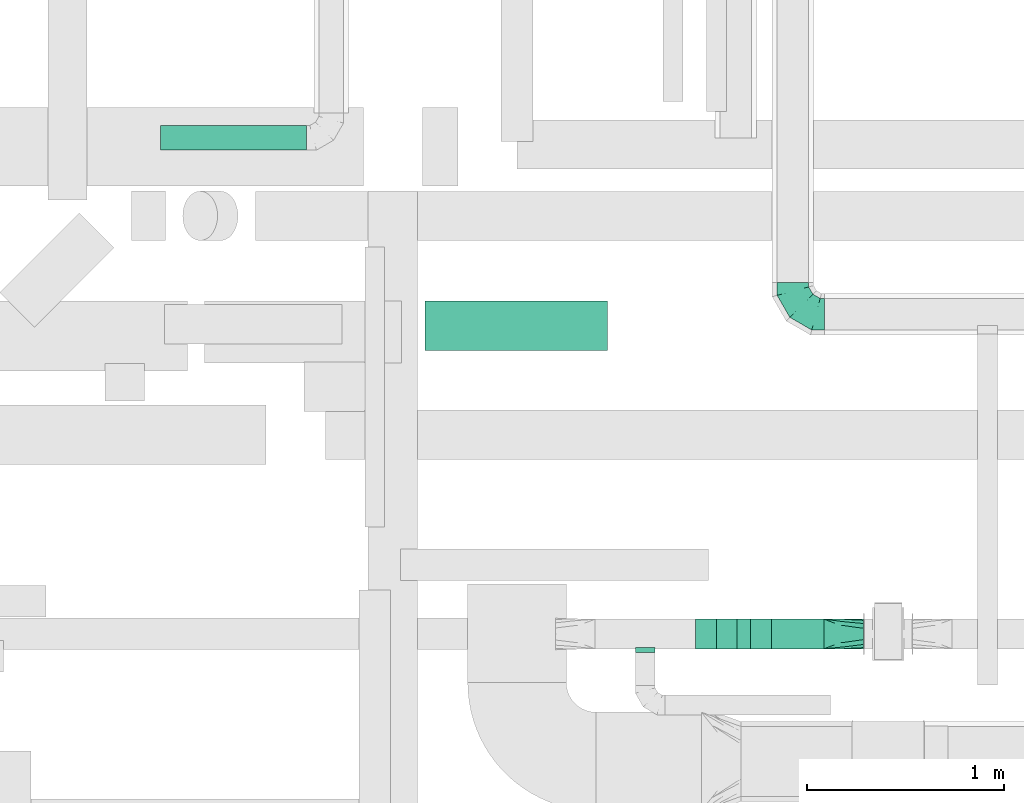
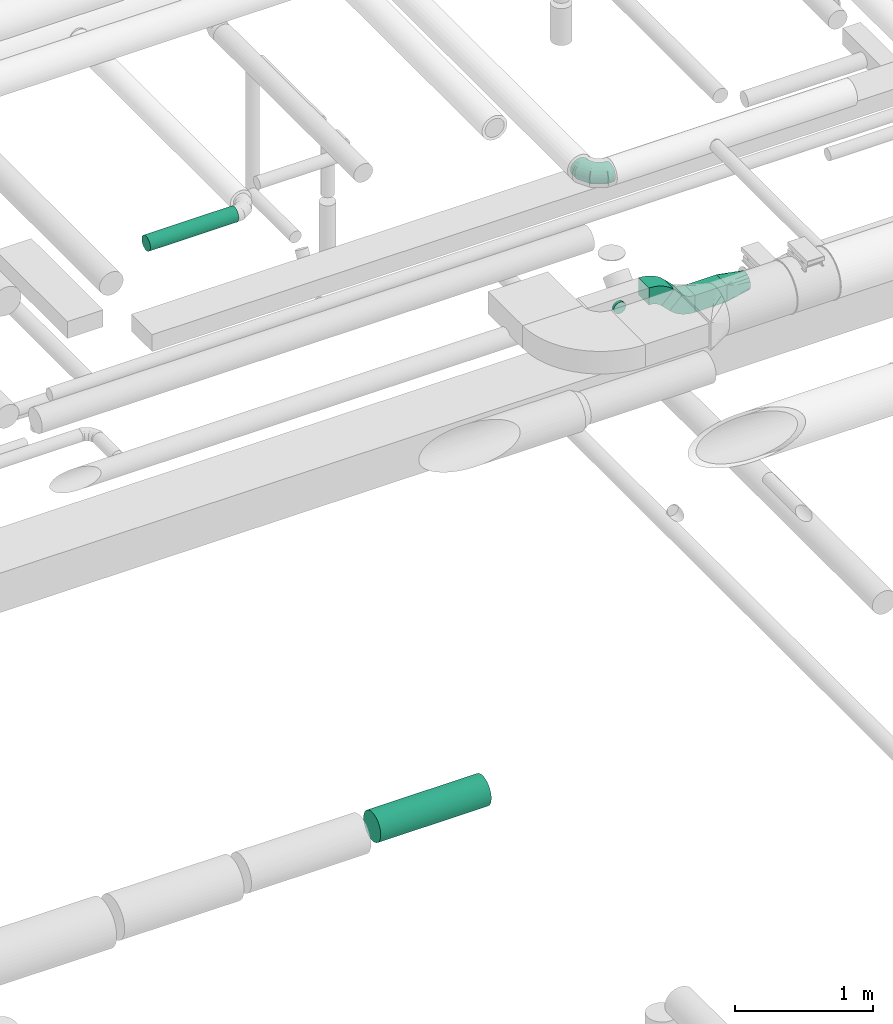
# One storey, part 210 of 337: 5 flow fittings, 4 flow segments.
"""IFC2X3 building model written with IfcOpenShell, lengths in millimetres."""

from ifc_helpers import new_model, entity, si_unit, converted_unit, derived_unit, direction, frame, frame_2d, origin, origin_2d_with_axis, place, context, subcontext, project, spatial, polyline, circle_curve, parameter, trimmed, segment, composite_curve, rectangle, circle, outline, extrude, faceted_brep, source, transform, mapped, material, type_object, type_shapes, element, save


model = new_model("IFC2X3")

# Units and contexts
model_context = context("Model", 3, precision=0.01, world=origin(), true_north=direction((6.12303176911189e-17, 1.0)))
body_context = subcontext(model_context, "Body", "Model", "MODEL_VIEW")
ifc_project = project(units=[si_unit("LENGTHUNIT", "METRE", prefix="MILLI"), si_unit("AREAUNIT", "SQUARE_METRE"), si_unit("VOLUMEUNIT", "CUBIC_METRE"), converted_unit("PLANEANGLEUNIT", "DEGREE", entity("IfcRatioMeasure", 0.0174532925199433), si_unit("PLANEANGLEUNIT", "RADIAN"), dimensions=[0, 0, 0, 0, 0, 0, 0]), si_unit("MASSUNIT", "GRAM", prefix="KILO"), derived_unit("MASSDENSITYUNIT", [(si_unit("MASSUNIT", "GRAM", prefix="KILO"), 1), (si_unit("LENGTHUNIT", "METRE"), -3)]), derived_unit("MOMENTOFINERTIAUNIT", [(si_unit("LENGTHUNIT", "METRE"), 4)]), si_unit("TIMEUNIT", "SECOND"), si_unit("FREQUENCYUNIT", "HERTZ"), si_unit("THERMODYNAMICTEMPERATUREUNIT", "DEGREE_CELSIUS"), derived_unit("THERMALTRANSMITTANCEUNIT", [(si_unit("MASSUNIT", "GRAM", prefix="KILO"), 1), (si_unit("THERMODYNAMICTEMPERATUREUNIT", "KELVIN"), -1), (si_unit("TIMEUNIT", "SECOND"), -3)]), derived_unit("VOLUMETRICFLOWRATEUNIT", [(si_unit("LENGTHUNIT", "METRE"), 3), (si_unit("TIMEUNIT", "SECOND"), -1)]), derived_unit("MASSFLOWRATEUNIT", [(si_unit("MASSUNIT", "GRAM", prefix="KILO"), 1), (si_unit("TIMEUNIT", "SECOND"), -1)]), derived_unit("ROTATIONALFREQUENCYUNIT", [(si_unit("TIMEUNIT", "SECOND"), -1)]), si_unit("ELECTRICCURRENTUNIT", "AMPERE"), si_unit("ELECTRICVOLTAGEUNIT", "VOLT"), si_unit("POWERUNIT", "WATT"), si_unit("FORCEUNIT", "NEWTON", prefix="KILO"), si_unit("ILLUMINANCEUNIT", "LUX"), si_unit("LUMINOUSFLUXUNIT", "LUMEN"), si_unit("LUMINOUSINTENSITYUNIT", "CANDELA"), derived_unit("USERDEFINED", [(si_unit("MASSUNIT", "GRAM", prefix="KILO"), -1), (si_unit("LENGTHUNIT", "METRE"), -2), (si_unit("TIMEUNIT", "SECOND"), 3), (si_unit("LUMINOUSFLUXUNIT", "LUMEN"), 1)]), derived_unit("LINEARVELOCITYUNIT", [(si_unit("LENGTHUNIT", "METRE"), 1), (si_unit("TIMEUNIT", "SECOND"), -1)]), si_unit("PRESSUREUNIT", "PASCAL"), derived_unit("USERDEFINED", [(si_unit("LENGTHUNIT", "METRE"), -2), (si_unit("MASSUNIT", "GRAM", prefix="KILO"), 1), (si_unit("TIMEUNIT", "SECOND"), -2)]), derived_unit("LINEARFORCEUNIT", [(si_unit("MASSUNIT", "GRAM", prefix="KILO"), 1), (si_unit("LENGTHUNIT", "METRE"), 1), (si_unit("TIMEUNIT", "SECOND"), -2), (si_unit("LENGTHUNIT", "METRE"), -1)]), derived_unit("PLANARFORCEUNIT", [(si_unit("MASSUNIT", "GRAM", prefix="KILO"), 1), (si_unit("LENGTHUNIT", "METRE"), 1), (si_unit("TIMEUNIT", "SECOND"), -2), (si_unit("LENGTHUNIT", "METRE"), -2)])], contexts=[model_context])

# Site, building, storey
site_placement = place(None, origin())
site = spatial("IfcSite", under=ifc_project, at=site_placement, CompositionType="ELEMENT")
building_placement = place(site_placement, origin())
building = spatial("IfcBuilding", under=site, at=building_placement, CompositionType="ELEMENT")
storey_placement = place(building_placement, origin())
storey = spatial("IfcBuildingStorey", under=building, at=storey_placement, CompositionType="ELEMENT", Elevation=0.0)

# Flow segments
duct_segment_type_1 = type_object("IfcDuctSegmentType", PredefinedType="NOTDEFINED")
flow_segment_1_placement = place(storey_placement, frame((61619.28, 4035.29, 2975.0)))
element("IfcFlowSegment", 1, at=flow_segment_1_placement, inside=storey, type_object=duct_segment_type_1, context=body_context, shape_type="SweptSolid", body=[
    extrude(rectangle(XDim=265.719999999986, YDim=150.0, at=origin_2d_with_axis()), frame((132.86, 75.0, 0.0), z_axis=(0.0, 0.0, 1.0), x_axis=(-1.0, 0.0, 0.0)), (0.0, 0.0, 1.0), 150.000000000001),
])
flow_segment_2_placement = place(storey_placement, frame((61338.95, 4035.29, 3062.87)))
element("IfcFlowSegment", 2, at=flow_segment_2_placement, inside=storey, type_object=duct_segment_type_1, context=body_context, shape_type="SweptSolid", body=[
    extrude(rectangle(XDim=96.4466094067255, YDim=150.0, at=origin_2d_with_axis()), frame((34.1, 75.0, 34.1), z_axis=(0.707106781186553, 0.0, 0.707106781186542), x_axis=(-0.707106781186542, 0.0, 0.707106781186553)), (0.0, 0.0, 1.0), 150.000000000016),
])
duct_segment_type_2 = type_object("IfcDuctSegmentType", PredefinedType="NOTDEFINED")
flow_segment_3_placement = place(storey_placement, frame((59863.39, 5546.63, -2076.6)))
element("IfcFlowSegment", 3, at=flow_segment_3_placement, inside=storey, type_object=duct_segment_type_2, context=body_context, shape_type="SweptSolid", body=[
    extrude(circle(Radius=125.0, at=origin_2d_with_axis()), frame((0.0, 126.6, 126.6), z_axis=(1.0, 0.0, 0.0), x_axis=(0.0, -1.0, 0.0)), (0.0, 0.0, 1.0), 925.254693962172),
])
flow_segment_4_placement = place(storey_placement, frame((58522.05, 6561.57, 3035.91)))
element("IfcFlowSegment", 4, at=flow_segment_4_placement, inside=storey, type_object=duct_segment_type_2, context=body_context, shape_type="SweptSolid", body=[
    extrude(circle(Radius=62.5, at=origin_2d_with_axis()), frame((0.0, 64.1, 64.1), z_axis=(1.0, 0.0, 0.0), x_axis=(0.0, 1.0, 0.0)), (0.0, 0.0, 1.0), 740.000070481089),
])

# Flow fittings
ifc_material = material()
duct_fitting_type_1 = type_object("IfcDuctFittingType", PredefinedType="NOTDEFINED", material=ifc_material)
shared_shape_1 = source(origin(), body_context, "Body", "Brep", [
    faceted_brep([(-160.0, 0.0, -80.0), (-160.0, -20.71, -77.27), (-160.0, -40.0, -69.28), (-160.0, -56.57, -56.57), (-160.0, -69.28, -40.0), (-160.0, -77.27, -20.71), (-160.0, -80.0, 0.0), (-160.0, -77.27, 20.71), (-160.0, -69.28, 40.0), (-160.0, -56.57, 56.57), (-160.0, -40.0, 69.28), (-160.0, -20.71, 77.27), (-160.0, 0.0, 80.0), (-160.0, 20.71, 77.27), (-160.0, 40.0, 69.28), (-160.0, 56.57, 56.57), (-160.0, 69.28, 40.0), (-160.0, 77.27, 20.71), (-160.0, 80.0, 0.0), (-160.0, 77.27, -20.71), (-160.0, 69.28, -40.0), (-160.0, 56.57, -56.57), (-160.0, 40.0, -69.28), (-160.0, 20.71, -77.27), (-122.68, 20.71, 77.27), (-127.85, 40.0, 69.28), (-117.13, 0.0, 80.0), (-132.29, 56.57, 56.57), (-137.83, 77.27, 20.71), (-138.56, 80.0, 0.0), (-135.69, 69.28, 40.0), (-135.69, 69.28, -40.0), (-132.29, 56.57, -56.57), (-137.83, 77.27, -20.71), (-122.68, 20.71, -77.27), (-117.13, 0.0, -80.0), (-127.85, 40.0, -69.28), (-111.58, -20.71, -77.27), (-106.41, -40.0, -69.28), (-101.97, -56.57, -56.57), (-98.56, -69.28, -40.0), (-96.42, -77.27, -20.71), (-95.69, -80.0, 0.0), (-96.42, -77.27, 20.71), (-98.56, -69.28, 40.0), (-101.97, -56.57, 56.57), (-106.41, -40.0, 69.28), (-111.58, -20.71, 77.27), (-58.03, 58.03, 77.27), (-72.15, 72.15, 69.28), (-42.87, 42.87, 80.0), (-84.28, 84.28, 56.57), (-93.59, 93.59, 40.0), (-99.44, 99.44, 20.71), (-101.44, 101.44, 0.0), (-99.44, 99.44, -20.71), (-93.59, 93.59, -40.0), (-84.28, 84.28, -56.57), (-58.03, 58.03, -77.27), (-42.87, 42.87, -80.0), (-72.15, 72.15, -69.28), (-27.71, 27.71, -77.27), (-13.59, 13.59, -69.28), (-1.46, 1.46, -56.57), (7.85, -7.85, -40.0), (13.7, -13.7, -20.71), (15.69, -15.69, 0.0), (13.7, -13.7, 20.71), (7.85, -7.85, 40.0), (-1.46, 1.46, 56.57), (-13.59, 13.59, 69.28), (-27.71, 27.71, 77.27), (-20.71, 122.68, 77.27), (-40.0, 127.85, 69.28), (0.0, 117.13, 80.0), (-56.57, 132.29, 56.57), (-69.28, 135.69, 40.0), (-77.27, 137.83, 20.71), (-80.0, 138.56, 0.0), (-77.27, 137.83, -20.71), (-69.28, 135.69, -40.0), (-56.57, 132.29, -56.57), (-20.71, 122.68, -77.27), (0.0, 117.13, -80.0), (-40.0, 127.85, -69.28), (20.71, 111.58, -77.27), (40.0, 106.41, -69.28), (56.57, 101.97, -56.57), (69.28, 98.56, -40.0), (77.27, 96.42, -20.71), (80.0, 95.69, 0.0), (77.27, 96.42, 20.71), (69.28, 98.56, 40.0), (56.57, 101.97, 56.57), (40.0, 106.41, 69.28), (20.71, 111.58, 77.27), (-20.71, 160.0, -77.27), (-40.0, 160.0, -69.28), (-56.57, 160.0, -56.57), (-69.28, 160.0, -40.0), (-77.27, 160.0, -20.71), (-80.0, 160.0, 0.0), (-77.27, 160.0, 20.71), (-69.28, 160.0, 40.0), (-56.57, 160.0, 56.57), (-40.0, 160.0, 69.28), (-20.71, 160.0, 77.27), (0.0, 160.0, 80.0), (20.71, 160.0, 77.27), (40.0, 160.0, 69.28), (56.57, 160.0, 56.57), (69.28, 160.0, 40.0), (77.27, 160.0, 20.71), (80.0, 160.0, 0.0), (77.27, 160.0, -20.71), (69.28, 160.0, -40.0), (56.57, 160.0, -56.57), (40.0, 160.0, -69.28), (20.71, 160.0, -77.27), (0.0, 160.0, -80.0)], [[[0, 1, 2, 3, 4, 5, 6, 7, 8, 9, 10, 11, 12, 13, 14, 15, 16, 17, 18, 19, 20, 21, 22, 23]], [[24, 25, 14, 13]], [[26, 24, 13, 12]], [[14, 25, 27, 15]], [[28, 29, 18, 17]], [[30, 28, 17, 16]], [[15, 27, 30, 16]], [[20, 31, 32, 21]], [[33, 31, 20, 19]], [[18, 29, 33, 19]], [[34, 35, 0, 23]], [[36, 34, 23, 22]], [[32, 36, 22, 21]], [[1, 0, 35, 37]], [[2, 1, 37, 38]], [[3, 2, 38, 39]], [[5, 4, 40, 41]], [[6, 5, 41, 42]], [[39, 40, 4, 3]], [[6, 42, 43, 7]], [[7, 43, 44, 8]], [[8, 44, 45, 9]], [[9, 45, 46, 10]], [[10, 46, 47, 11]], [[26, 12, 11, 47]], [[48, 49, 25, 24]], [[50, 48, 24, 26]], [[27, 25, 49, 51]], [[52, 53, 28, 30]], [[51, 52, 30, 27]], [[29, 28, 53, 54]], [[55, 56, 31, 33]], [[54, 55, 33, 29]], [[32, 31, 56, 57]], [[58, 59, 35, 34]], [[60, 58, 34, 36]], [[57, 60, 36, 32]], [[37, 35, 59, 61]], [[38, 37, 61, 62]], [[39, 38, 62, 63]], [[41, 40, 64, 65]], [[42, 41, 65, 66]], [[63, 64, 40, 39]], [[43, 42, 66, 67]], [[44, 43, 67, 68]], [[68, 69, 45, 44]], [[46, 45, 69, 70]], [[47, 46, 70, 71]], [[26, 47, 71, 50]], [[72, 73, 49, 48]], [[74, 72, 48, 50]], [[51, 49, 73, 75]], [[76, 77, 53, 52]], [[75, 76, 52, 51]], [[54, 53, 77, 78]], [[79, 80, 56, 55]], [[78, 79, 55, 54]], [[57, 56, 80, 81]], [[82, 83, 59, 58]], [[84, 82, 58, 60]], [[81, 84, 60, 57]], [[61, 59, 83, 85]], [[62, 61, 85, 86]], [[63, 62, 86, 87]], [[65, 64, 88, 89]], [[66, 65, 89, 90]], [[87, 88, 64, 63]], [[67, 66, 90, 91]], [[68, 67, 91, 92]], [[92, 93, 69, 68]], [[70, 69, 93, 94]], [[71, 70, 94, 95]], [[50, 71, 95, 74]], [[96, 97, 98, 99, 100, 101, 102, 103, 104, 105, 106, 107, 108, 109, 110, 111, 112, 113, 114, 115, 116, 117, 118, 119]], [[72, 74, 107, 106]], [[73, 72, 106, 105]], [[75, 73, 105, 104]], [[77, 76, 103, 102]], [[78, 77, 102, 101]], [[75, 104, 103, 76]], [[78, 101, 100, 79]], [[79, 100, 99, 80]], [[80, 99, 98, 81]], [[84, 97, 96, 82]], [[82, 96, 119, 83]], [[84, 81, 98, 97]], [[118, 117, 86, 85]], [[119, 118, 85, 83]], [[116, 87, 86, 117]], [[88, 115, 114, 89]], [[89, 114, 113, 90]], [[115, 88, 87, 116]], [[112, 111, 92, 91]], [[113, 112, 91, 90]], [[111, 110, 93, 92]], [[95, 94, 109, 108]], [[74, 95, 108, 107]], [[110, 109, 94, 93]]]),
])
type_shapes(duct_fitting_type_1, [shared_shape_1])
flow_fitting_1_placement = place(storey_placement, frame((61727.4, 5731.17, 3100.0), z_axis=(0.0, 0.0, 1.0), x_axis=(0.0, -1.0, 0.0)))
element("IfcFlowFitting", 5, at=flow_fitting_1_placement, inside=storey, type_object=duct_fitting_type_1, material=ifc_material, context=body_context, shape_type="MappedRepresentation", body=[
    mapped(shared_shape_1, transform((0.0, 0.0, 0.0), scale=1.0)),
])
duct_fitting_type_2 = type_object("IfcDuctFittingType", PredefinedType="NOTDEFINED", material=ifc_material)
shared_shape_2 = source(origin(), body_context, "Body", "Brep", [
    faceted_brep([(20.0, 0.0, -50.0), (20.0, 12.94, -48.3), (20.0, 25.0, -43.3), (20.0, 35.36, -35.36), (20.0, 43.3, -25.0), (20.0, 48.3, -12.94), (20.0, 50.0, 0.0), (20.0, 48.3, 12.94), (20.0, 43.3, 25.0), (20.0, 35.36, 35.36), (20.0, 25.0, 43.3), (20.0, 12.94, 48.3), (20.0, 0.0, 50.0), (20.0, -12.94, 48.3), (20.0, -25.0, 43.3), (20.0, -35.36, 35.36), (20.0, -43.3, 25.0), (20.0, -48.3, 12.94), (20.0, -50.0, 0.0), (20.0, -48.3, -12.94), (20.0, -43.3, -25.0), (20.0, -35.36, -35.36), (20.0, -25.0, -43.3), (20.0, -12.94, -48.3), (0.0, 0.0, 50.0), (-6.1, 0.0, 50.0), (-6.1, -12.94, 48.3), (0.0, -12.94, 48.3), (-6.1, -25.0, 43.3), (0.0, -25.0, 43.3), (0.0, -35.36, 35.36), (-6.1, -35.36, 35.36), (0.0, -43.3, 25.0), (-6.1, -43.3, 25.0), (-6.1, -48.3, 12.94), (0.0, -48.3, 12.94), (-6.1, -50.0, 0.0), (0.0, -50.0, 0.0), (-6.1, -48.3, -12.94), (0.0, -48.3, -12.94), (-6.1, -43.3, -25.0), (0.0, -43.3, -25.0), (0.0, -35.36, -35.36), (-6.1, -35.36, -35.36), (0.0, -25.0, -43.3), (-6.1, -25.0, -43.3), (-6.1, -12.94, -48.3), (0.0, -12.94, -48.3), (-6.1, 0.0, -50.0), (0.0, 0.0, -50.0), (-6.1, 12.94, -48.3), (0.0, 12.94, -48.3), (-6.1, 25.0, -43.3), (0.0, 25.0, -43.3), (0.0, 35.36, -35.36), (-6.1, 35.36, -35.36), (0.0, 43.3, -25.0), (-6.1, 43.3, -25.0), (-6.1, 48.3, -12.94), (0.0, 48.3, -12.94), (-6.1, 50.0, 0.0), (0.0, 50.0, 0.0), (-6.1, 48.3, 12.94), (0.0, 48.3, 12.94), (-6.1, 43.3, 25.0), (0.0, 43.3, 25.0), (0.0, 35.36, 35.36), (-6.1, 35.36, 35.36), (0.0, 25.0, 43.3), (-6.1, 25.0, 43.3), (-6.1, 12.94, 48.3), (0.0, 12.94, 48.3)], [[[0, 1, 2, 3, 4, 5, 6, 7, 8, 9, 10, 11, 12, 13, 14, 15, 16, 17, 18, 19, 20, 21, 22, 23]], [[13, 12, 24, 25, 26, 27]], [[14, 13, 27, 26, 28, 29]], [[30, 15, 14, 29, 28, 31]], [[17, 16, 32, 33, 34, 35]], [[18, 17, 35, 34, 36, 37]], [[32, 16, 15, 30, 31, 33]], [[19, 18, 37, 36, 38, 39]], [[20, 19, 39, 38, 40, 41]], [[42, 21, 20, 41, 40, 43]], [[23, 22, 44, 45, 46, 47]], [[0, 23, 47, 46, 48, 49]], [[44, 22, 21, 42, 43, 45]], [[1, 0, 49, 48, 50, 51]], [[2, 1, 51, 50, 52, 53]], [[54, 3, 2, 53, 52, 55]], [[5, 4, 56, 57, 58, 59]], [[6, 5, 59, 58, 60, 61]], [[56, 4, 3, 54, 55, 57]], [[7, 6, 61, 60, 62, 63]], [[8, 7, 63, 62, 64, 65]], [[66, 9, 8, 65, 64, 67]], [[11, 10, 68, 69, 70, 71]], [[12, 11, 71, 70, 25, 24]], [[68, 10, 9, 66, 67, 69]], [[46, 45, 43, 40, 38, 36, 34, 33, 31, 28, 26, 25, 70, 69, 67, 64, 62, 60, 58, 57, 55, 52, 50, 48]]]),
])
type_shapes(duct_fitting_type_2, [shared_shape_2])
flow_fitting_2_placement = place(storey_placement, frame((60978.74, 4035.29, 3250.0), z_axis=(0.0, 0.0, -1.0), x_axis=(0.0, -1.0, 0.0)))
element("IfcFlowFitting", 6, at=flow_fitting_2_placement, inside=storey, type_object=duct_fitting_type_2, material=ifc_material, context=body_context, shape_type="MappedRepresentation", body=[
    mapped(shared_shape_2, transform((0.0, 0.0, 0.0), scale=1.0)),
])
duct_fitting_type_3 = type_object("IfcDuctFittingType", PredefinedType="NOTDEFINED", material=ifc_material)
shared_shape_3 = source(origin(), body_context, "Body", "Brep", [
    faceted_brep([(200.0, 53.03, 53.03), (200.0, 46.95, 57.1), (200.0, 40.87, 61.16), (200.0, 34.78, 65.23), (200.0, 28.7, 69.29), (200.0, 21.44, 70.74), (200.0, 14.17, 72.18), (200.0, 10.63, 72.89), (200.0, 7.09, 73.59), (200.0, 0.0, 75.0), (200.0, -7.09, 73.59), (200.0, -14.17, 72.18), (200.0, -17.81, 71.46), (200.0, -21.44, 70.74), (200.0, -28.7, 69.29), (200.0, -34.78, 65.23), (200.0, -40.87, 61.16), (200.0, -46.95, 57.1), (200.0, -53.03, 53.03), (200.0, -57.1, 46.95), (200.0, -61.16, 40.87), (200.0, -65.23, 34.78), (200.0, -69.29, 28.7), (200.0, -70.74, 21.44), (200.0, -72.18, 14.17), (200.0, -72.89, 10.63), (200.0, -73.59, 7.09), (200.0, -75.0, 0.0), (200.0, -73.59, -7.09), (200.0, -72.18, -14.17), (200.0, -71.46, -17.81), (200.0, -70.74, -21.44), (200.0, -69.29, -28.7), (200.0, -65.23, -34.78), (200.0, -61.16, -40.87), (200.0, -57.1, -46.95), (200.0, -53.03, -53.03), (200.0, -46.95, -57.1), (200.0, -40.87, -61.16), (200.0, -34.78, -65.23), (200.0, -28.7, -69.29), (200.0, -21.44, -70.74), (200.0, -14.17, -72.18), (200.0, -10.63, -72.89), (200.0, -7.09, -73.59), (200.0, 0.0, -75.0), (200.0, 7.09, -73.59), (200.0, 14.17, -72.18), (200.0, 17.81, -71.46), (200.0, 21.44, -70.74), (200.0, 28.7, -69.29), (200.0, 34.78, -65.23), (200.0, 40.87, -61.16), (200.0, 46.95, -57.1), (200.0, 53.03, -53.03), (200.0, 57.1, -46.95), (200.0, 61.16, -40.87), (200.0, 65.23, -34.78), (200.0, 69.29, -28.7), (200.0, 70.74, -21.44), (200.0, 72.18, -14.17), (200.0, 72.89, -10.63), (200.0, 73.59, -7.09), (200.0, 75.0, 0.0), (200.0, 73.59, 7.09), (200.0, 72.18, 14.17), (200.0, 71.46, 17.81), (200.0, 70.74, 21.44), (200.0, 69.29, 28.7), (200.0, 65.23, 34.78), (200.0, 61.16, 40.87), (200.0, 57.1, 46.95), (0.0, -75.0, 75.0), (0.0, 75.0, 75.0), (0.0, 75.0, -75.0), (0.0, -75.0, -75.0), (52.06, -55.48, 75.0), (78.09, -45.72, 75.0), (176.03, -8.99, 75.0), (152.06, -17.98, 75.0), (128.09, -26.97, 75.0), (104.11, -35.96, 75.0), (100.0, -65.57, 62.36), (78.09, -75.0, 45.72), (104.11, -75.0, 35.96), (128.09, -75.0, 26.97), (152.06, -75.0, 17.98), (164.04, -75.0, 13.48), (176.03, -75.0, 8.99), (26.03, -75.0, 65.24), (52.06, -75.0, 55.48), (26.03, -65.24, 75.0), (26.03, -75.0, -65.24), (52.06, -75.0, -55.48), (78.09, -75.0, -45.72), (104.11, -75.0, -35.96), (128.09, -75.0, -26.97), (152.06, -75.0, -17.98), (176.03, -75.0, -8.99), (100.0, -62.36, -65.57), (78.09, -45.72, -75.0), (104.11, -35.96, -75.0), (128.09, -26.97, -75.0), (152.06, -17.98, -75.0), (164.04, -13.48, -75.0), (176.03, -8.99, -75.0), (26.03, -65.24, -75.0), (52.06, -55.48, -75.0), (26.03, 65.24, -75.0), (52.06, 55.48, -75.0), (78.09, 45.72, -75.0), (104.11, 35.96, -75.0), (128.09, 26.97, -75.0), (152.06, 17.98, -75.0), (176.03, 8.99, -75.0), (100.0, 65.57, -62.36), (78.09, 75.0, -45.72), (104.11, 75.0, -35.96), (128.09, 75.0, -26.97), (152.06, 75.0, -17.98), (164.04, 75.0, -13.48), (176.03, 75.0, -8.99), (26.03, 75.0, -65.24), (52.06, 75.0, -55.48), (26.03, 75.0, 65.24), (52.06, 75.0, 55.48), (78.09, 75.0, 45.72), (104.11, 75.0, 35.96), (128.09, 75.0, 26.97), (152.06, 75.0, 17.98), (176.03, 75.0, 8.99), (100.0, 62.36, 65.57), (78.09, 45.72, 75.0), (104.11, 35.96, 75.0), (128.09, 26.97, 75.0), (152.06, 17.98, 75.0), (164.04, 13.48, 75.0), (176.03, 8.99, 75.0), (26.03, 65.24, 75.0), (52.06, 55.48, 75.0)], [[[0, 1, 2, 3, 4, 5, 6, 7, 8, 9, 10, 11, 12, 13, 14, 15, 16, 17, 18, 19, 20, 21, 22, 23, 24, 25, 26, 27, 28, 29, 30, 31, 32, 33, 34, 35, 36, 37, 38, 39, 40, 41, 42, 43, 44, 45, 46, 47, 48, 49, 50, 51, 52, 53, 54, 55, 56, 57, 58, 59, 60, 61, 62, 63, 64, 65, 66, 67, 68, 69, 70, 71]], [[72, 73, 74, 75]], [[76, 16, 77]], [[16, 15, 14, 77]], [[78, 79, 80, 81, 77, 14, 13, 12, 11, 10, 9]], [[17, 82, 18]], [[24, 23, 22, 83, 84, 85, 86, 87, 88, 27, 26, 25]], [[82, 72, 89]], [[82, 19, 18]], [[83, 20, 90]], [[91, 72, 82]], [[22, 21, 20, 83]], [[90, 20, 19]], [[19, 82, 89]], [[90, 19, 89]], [[76, 17, 16]], [[17, 76, 91]], [[82, 17, 91]], [[88, 87, 86, 85, 84, 83, 90, 89, 72, 75, 92, 93, 94, 95, 96, 97, 98, 27]], [[93, 34, 94]], [[34, 33, 32, 94]], [[98, 97, 96, 95, 94, 32, 31, 30, 29, 28, 27]], [[35, 99, 36]], [[42, 41, 40, 100, 101, 102, 103, 104, 105, 45, 44, 43]], [[99, 75, 106]], [[99, 37, 36]], [[100, 38, 107]], [[92, 75, 99]], [[40, 39, 38, 100]], [[107, 38, 37]], [[37, 99, 106]], [[107, 37, 106]], [[93, 35, 34]], [[35, 93, 92]], [[99, 35, 92]], [[105, 104, 103, 102, 101, 100, 107, 106, 75, 74, 108, 109, 110, 111, 112, 113, 114, 45]], [[109, 52, 110]], [[52, 51, 50, 110]], [[114, 113, 112, 111, 110, 50, 49, 48, 47, 46, 45]], [[53, 115, 54]], [[60, 59, 58, 116, 117, 118, 119, 120, 121, 63, 62, 61]], [[115, 74, 122]], [[115, 55, 54]], [[116, 56, 123]], [[108, 74, 115]], [[58, 57, 56, 116]], [[123, 56, 55]], [[55, 115, 122]], [[123, 55, 122]], [[109, 53, 52]], [[53, 109, 108]], [[115, 53, 108]], [[74, 73, 124, 125, 126, 127, 128, 129, 130, 63, 121, 120, 119, 118, 117, 116, 123, 122]], [[125, 70, 126]], [[70, 69, 68, 126]], [[130, 129, 128, 127, 126, 68, 67, 66, 65, 64, 63]], [[71, 131, 0]], [[6, 5, 4, 132, 133, 134, 135, 136, 137, 9, 8, 7]], [[131, 73, 138]], [[131, 1, 0]], [[132, 2, 139]], [[124, 73, 131]], [[4, 3, 2, 132]], [[139, 2, 1]], [[1, 131, 138]], [[139, 1, 138]], [[125, 71, 70]], [[71, 125, 124]], [[131, 71, 124]], [[73, 72, 91, 76, 77, 81, 80, 79, 78, 9, 137, 136, 135, 134, 133, 132, 139, 138]]]),
])
type_shapes(duct_fitting_type_3, [shared_shape_3])
flow_fitting_3_placement = place(storey_placement, frame((61885.0, 4110.29, 3050.0)))
element("IfcFlowFitting", 7, at=flow_fitting_3_placement, inside=storey, type_object=duct_fitting_type_3, material=ifc_material, context=body_context, shape_type="MappedRepresentation", body=[
    mapped(shared_shape_3, transform((0.0, 0.0, 0.0), scale=1.0)),
])
duct_fitting_type_4 = type_object("IfcDuctFittingType", PredefinedType="NOTDEFINED", material=ifc_material)
shared_shape_4 = source(origin(), body_context, "Body", "SweptSolid", [
    extrude(outline(composite_curve([segment(polyline([(-107.95, -79.55), (42.05, -79.55)]), True, "CONTINUOUS"), segment(trimmed(circle_curve(frame_2d((192.05, -79.55), x_axis=(-0.707106781186546, 0.707106781186546)), 150.0), [parameter(0.0)], [parameter(45.0)], True, "PARAMETER"), False, "CONTINUOUS"), segment(polyline([(85.98, 26.52), (-20.08, 132.58)]), True, "CONTINUOUS"), segment(trimmed(circle_curve(frame_2d((192.05, -79.55), x_axis=(-0.707106781186546, 0.707106781186546)), 300.0), [parameter(0.0)], [parameter(45.0)], True, "PARAMETER"), True, "CONTINUOUS")], self_intersect=False)), frame((-13.65, 32.95, -75.0), z_axis=(0.0, 0.0, 1.0), x_axis=(-0.707106781186547, 0.707106781186548, 0.0)), (0.0, 0.0, 1.0), 150.0),
])
type_shapes(duct_fitting_type_4, [shared_shape_4])
for number, where, z_axis, x_axis in (
    (8, (61526.08, 4110.29, 3050.0), (0.0, 1.0, 0.0), (-1.0, 0.0, 0.0)),
    (9, (61326.08, 4110.29, 3250.0), (0.0, -1.0, 0.0), (-0.707106781186499, 0.0, 0.707106781186596)),
):
    element("IfcFlowFitting", number, at=place(storey_placement, frame(where, z_axis=z_axis, x_axis=x_axis)), inside=storey, type_object=duct_fitting_type_4, material=ifc_material, context=body_context, shape_type="MappedRepresentation", body=[
        mapped(shared_shape_4, transform((0.0, 0.0, 0.0), scale=1.0)),
    ])

save(model, "model.ifc")
